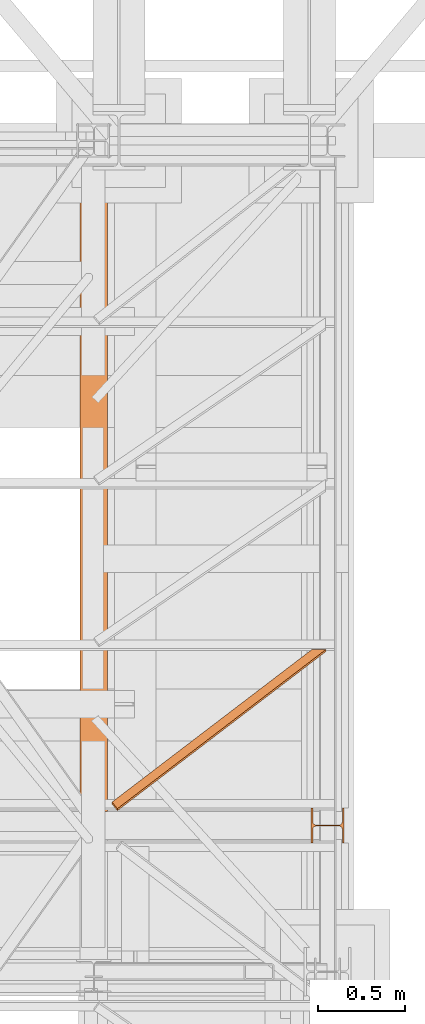
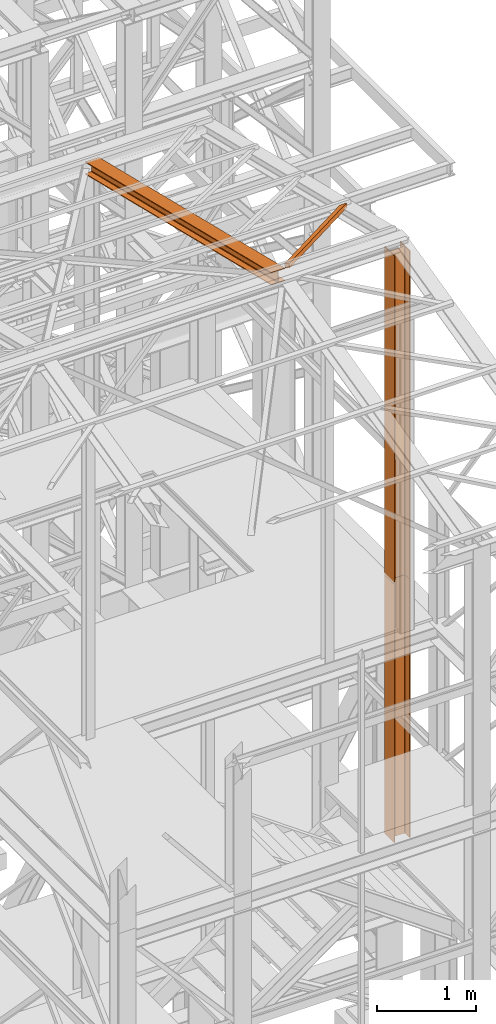
# One storey, part 65 of 208: 4 proxies.
"""IFC2X3 building model written with IfcOpenShell, lengths in millimetres."""

from ifc_helpers import new_model, entity, si_unit, converted_unit, frame, origin, origin_with_axes, place, context, subcontext, project, spatial, faceted_brep, element, save


model = new_model("IFC2X3")

# Units and contexts
model_context = context("Model", 3, precision=1e-05, world=origin())
plan_context = context("Plan", 3, precision=1e-05, world=origin())
body_context = subcontext(model_context, "Body", "Model", "MODEL_VIEW")
ifc_project = project(units=[si_unit("LENGTHUNIT", "METRE", prefix="MILLI"), converted_unit("PLANEANGLEUNIT", "DEGREE", entity("IfcPlaneAngleMeasure", 0.0174532925199433), si_unit("PLANEANGLEUNIT", "RADIAN"), dimensions=[0, 0, 0, 0, 0, 0, 0]), si_unit("AREAUNIT", "SQUARE_METRE"), si_unit("VOLUMEUNIT", "CUBIC_METRE")], contexts=[model_context, plan_context])

# Building, storey
building_placement = place(None, origin())
building = spatial("IfcBuilding", under=ifc_project, at=building_placement, CompositionType="COMPLEX")
storey_placement = place(building_placement, origin_with_axes())
storey = spatial("IfcBuildingStorey", under=building, at=storey_placement, Name="Geschoss", CompositionType="ELEMENT")

# Proxies
proxy_1_placement = place(storey_placement, frame((6603.254953595133, -21317.574391808, 5284.990005364416), z_axis=(0.0, 0.0, 1.0), x_axis=(1.0, 0.0, 0.0)))
element("IfcBuildingElementProxy", 1, at=proxy_1_placement, inside=storey, context=body_context, shape_type="Brep", body=[
    faceted_brep([(0.01000000000021828, 0.00999999999839929, 3200.009996721741), (0.01000000000021828, 200.0100029802306, 3200.009996721741), (10.00999791383765, 200.0100029802306, 3200.009996721741), (10.01000536441825, 121.2600035762771, 3200.009996721741), (11.87455041170142, 111.9441915473326, 3200.009996721741), (18.69419349193595, 105.1245498640819, 3200.009996721741), (28.01000458955787, 103.2600015571697, 3200.009996721741), (162.0100153779986, 103.2600015571697, 3200.009996721741), (171.3258264756205, 105.1245498640819, 3200.009996721741), (178.145469555855, 111.9441915473326, 3200.009996721741), (180.0100146031382, 121.2600035762771, 3200.009996721741), (180.0100146031382, 200.0100029802306, 3200.009996721741), (190.0100125169756, 200.0100029802306, 3200.009996721741), (190.0100125169756, 0.00999999999839929, 3200.009996721741), (180.0100146031382, 0.00999999999839929, 3200.009996721741), (180.0100146031382, 78.75999940395195, 3200.009996721741), (178.145469555855, 88.07581143289644, 3200.009996721741), (171.3258264756205, 94.89545311614711, 3200.009996721741), (162.0100153779986, 96.7600014230593, 3200.009996721741), (28.01000458955787, 96.7600014230593, 3200.009996721741), (18.69419349193595, 94.89545311614711, 3200.009996721741), (11.87455041170142, 88.07581143289644, 3200.009996721741), (10.01000536441825, 78.75999940395195, 3200.009996721741), (10.00999791383765, 0.00999999999839929, 3200.009996721741), (0.01000000000021828, 200.0100029802306, 3200.009996721741), (0.01000000000021828, 0.00999999999839929, 3200.009996721741), (0.01000000000021828, 0.00999999999839929, 0.009999999999308784), (0.01000000000021828, 200.0100029802306, 0.009999999999308784), (10.00999791383765, 200.0100029802306, 3200.009996721741), (0.01000000000021828, 200.0100029802306, 3200.009996721741), (0.01000000000021828, 200.0100029802306, 0.009999999999308784), (10.00999791383765, 200.0100029802306, 0.009999999999308784), (10.01000536441825, 121.2600035762771, 3200.009996721741), (10.00999791383765, 200.0100029802306, 3200.009996721741), (10.00999791383765, 200.0100029802306, 0.009999999999308784), (10.01000536441825, 121.2600035762771, 0.009999999999308784), (11.87455041170142, 111.9441915473326, 3200.009996721741), (10.01000536441825, 121.2600035762771, 3200.009996721741), (10.01000536441825, 121.2600035762771, 0.009999999999308784), (11.87455041170142, 111.9441915473326, 0.009999999999308784), (18.69419349193595, 105.1245498640819, 3200.009996721741), (11.87455041170142, 111.9441915473326, 3200.009996721741), (11.87455041170142, 111.9441915473326, 0.009999999999308784), (18.69419349193595, 105.1245498640819, 0.009999999999308784), (28.01000458955787, 103.2600015571697, 3200.009996721741), (18.69419349193595, 105.1245498640819, 3200.009996721741), (18.69419349193595, 105.1245498640819, 0.009999999999308784), (28.01000458955787, 103.2600015571697, 0.009999999999308784), (162.0100153779986, 103.2600015571697, 3200.009996721741), (28.01000458955787, 103.2600015571697, 3200.009996721741), (28.01000458955787, 103.2600015571697, 0.009999999999308784), (162.0100153779986, 103.2600015571697, 0.009999999999308784), (171.3258264756205, 105.1245498640819, 3200.009996721741), (162.0100153779986, 103.2600015571697, 3200.009996721741), (162.0100153779986, 103.2600015571697, 0.009999999999308784), (171.3258264756205, 105.1245498640819, 0.009999999999308784), (178.145469555855, 111.9441915473326, 3200.009996721741), (171.3258264756205, 105.1245498640819, 3200.009996721741), (171.3258264756205, 105.1245498640819, 0.009999999999308784), (178.145469555855, 111.9441915473326, 0.009999999999308784), (180.0100146031382, 121.2600035762771, 3200.009996721741), (178.145469555855, 111.9441915473326, 3200.009996721741), (178.145469555855, 111.9441915473326, 0.009999999999308784), (180.0100146031382, 121.2600035762771, 0.009999999999308784), (180.0100146031382, 200.0100029802306, 3200.009996721741), (180.0100146031382, 121.2600035762771, 3200.009996721741), (180.0100146031382, 121.2600035762771, 0.009999999999308784), (180.0100146031382, 200.0100029802306, 0.009999999999308784), (190.0100125169756, 200.0100029802306, 3200.009996721741), (180.0100146031382, 200.0100029802306, 3200.009996721741), (180.0100146031382, 200.0100029802306, 0.009999999999308784), (190.0100125169756, 200.0100029802306, 0.009999999999308784), (190.0100125169756, 0.00999999999839929, 3200.009996721741), (190.0100125169756, 200.0100029802306, 3200.009996721741), (190.0100125169756, 200.0100029802306, 0.009999999999308784), (190.0100125169756, 0.00999999999839929, 0.009999999999308784), (180.0100146031382, 0.00999999999839929, 3200.009996721741), (190.0100125169756, 0.00999999999839929, 3200.009996721741), (190.0100125169756, 0.00999999999839929, 0.009999999999308784), (180.0100146031382, 0.00999999999839929, 0.009999999999308784), (180.0100146031382, 78.75999940395195, 3200.009996721741), (180.0100146031382, 0.00999999999839929, 3200.009996721741), (180.0100146031382, 0.00999999999839929, 0.009999999999308784), (180.0100146031382, 78.75999940395195, 0.009999999999308784), (178.145469555855, 88.07581143289644, 3200.009996721741), (180.0100146031382, 78.75999940395195, 3200.009996721741), (180.0100146031382, 78.75999940395195, 0.009999999999308784), (178.145469555855, 88.07581143289644, 0.009999999999308784), (171.3258264756205, 94.89545311614711, 3200.009996721741), (178.145469555855, 88.07581143289644, 3200.009996721741), (178.145469555855, 88.07581143289644, 0.009999999999308784), (171.3258264756205, 94.89545311614711, 0.009999999999308784), (162.0100153779986, 96.7600014230593, 3200.009996721741), (171.3258264756205, 94.89545311614711, 3200.009996721741), (171.3258264756205, 94.89545311614711, 0.009999999999308784), (162.0100153779986, 96.7600014230593, 0.009999999999308784), (28.01000458955787, 96.7600014230593, 3200.009996721741), (162.0100153779986, 96.7600014230593, 3200.009996721741), (162.0100153779986, 96.7600014230593, 0.009999999999308784), (28.01000458955787, 96.7600014230593, 0.009999999999308784), (18.69419349193595, 94.89545311614711, 3200.009996721741), (28.01000458955787, 96.7600014230593, 3200.009996721741), (28.01000458955787, 96.7600014230593, 0.009999999999308784), (18.69419349193595, 94.89545311614711, 0.009999999999308784), (11.87455041170142, 88.07581143289644, 3200.009996721741), (18.69419349193595, 94.89545311614711, 3200.009996721741), (18.69419349193595, 94.89545311614711, 0.009999999999308784), (11.87455041170142, 88.07581143289644, 0.009999999999308784), (10.01000536441825, 78.75999940395195, 3200.009996721741), (11.87455041170142, 88.07581143289644, 3200.009996721741), (11.87455041170142, 88.07581143289644, 0.009999999999308784), (10.01000536441825, 78.75999940395195, 0.009999999999308784), (10.00999791383765, 0.00999999999839929, 3200.009996721741), (10.01000536441825, 78.75999940395195, 3200.009996721741), (10.01000536441825, 78.75999940395195, 0.009999999999308784), (10.00999791383765, 0.00999999999839929, 0.009999999999308784), (0.01000000000021828, 0.00999999999839929, 3200.009996721741), (10.00999791383765, 0.00999999999839929, 3200.009996721741), (10.00999791383765, 0.00999999999839929, 0.009999999999308784), (0.01000000000021828, 0.00999999999839929, 0.009999999999308784), (0.01000000000021828, 0.00999999999839929, 0.009999999999308784), (10.00999791383765, 0.00999999999839929, 0.009999999999308784), (10.01000536441825, 78.75999940395195, 0.009999999999308784), (11.87455041170142, 88.07581143289644, 0.009999999999308784), (18.69419349193595, 94.89545311614711, 0.009999999999308784), (28.01000458955787, 96.7600014230593, 0.009999999999308784), (162.0100153779986, 96.7600014230593, 0.009999999999308784), (171.3258264756205, 94.89545311614711, 0.009999999999308784), (178.145469555855, 88.07581143289644, 0.009999999999308784), (180.0100146031382, 78.75999940395195, 0.009999999999308784), (180.0100146031382, 0.00999999999839929, 0.009999999999308784), (190.0100125169756, 0.00999999999839929, 0.009999999999308784), (190.0100125169756, 200.0100029802306, 0.009999999999308784), (180.0100146031382, 200.0100029802306, 0.009999999999308784), (180.0100146031382, 121.2600035762771, 0.009999999999308784), (178.145469555855, 111.9441915473326, 0.009999999999308784), (171.3258264756205, 105.1245498640819, 0.009999999999308784), (162.0100153779986, 103.2600015571697, 0.009999999999308784), (28.01000458955787, 103.2600015571697, 0.009999999999308784), (18.69419349193595, 105.1245498640819, 0.009999999999308784), (11.87455041170142, 111.9441915473326, 0.009999999999308784), (10.01000536441825, 121.2600035762771, 0.009999999999308784), (10.00999791383765, 200.0100029802306, 0.009999999999308784), (0.01000000000021828, 200.0100029802306, 0.009999999999308784)], [[[0, 1, 2, 3, 4, 5, 6, 7, 8, 9, 10, 11, 12, 13, 14, 15, 16, 17, 18, 19, 20, 21, 22, 23]], [[24, 25, 26, 27]], [[28, 29, 30, 31]], [[32, 33, 34, 35]], [[36, 37, 38, 39]], [[40, 41, 42, 43]], [[44, 45, 46, 47]], [[48, 49, 50, 51]], [[52, 53, 54, 55]], [[56, 57, 58, 59]], [[60, 61, 62, 63]], [[64, 65, 66, 67]], [[68, 69, 70, 71]], [[72, 73, 74, 75]], [[76, 77, 78, 79]], [[80, 81, 82, 83]], [[84, 85, 86, 87]], [[88, 89, 90, 91]], [[92, 93, 94, 95]], [[96, 97, 98, 99]], [[100, 101, 102, 103]], [[104, 105, 106, 107]], [[108, 109, 110, 111]], [[112, 113, 114, 115]], [[116, 117, 118, 119]], [[120, 121, 122, 123, 124, 125, 126, 127, 128, 129, 130, 131, 132, 133, 134, 135, 136, 137, 138, 139, 140, 141, 142, 143]]], orient=[[False], [False], [False], [False], [False], [False], [False], [False], [False], [False], [False], [False], [False], [False], [False], [False], [False], [False], [False], [False], [False], [False], [False], [False], [False], [False]]),
])
proxy_2_placement = place(storey_placement, frame((6603.25496227017, -21317.57439178015, 8484.990002086157), z_axis=(0.0, 0.0, 1.0), x_axis=(1.0, 0.0, 0.0)))
element("IfcBuildingElementProxy", 2, at=proxy_2_placement, inside=storey, context=body_context, shape_type="Brep", body=[
    faceted_brep([(0.01000000000021828, 0.01000864719753736, 4065.914535727219), (0.01000000000021828, 200.0100116274298, 4065.914535727219), (10.00999791383765, 200.0100116274298, 4065.914535727219), (10.01000536441825, 121.2600122234762, 4065.914535727219), (11.87455041170142, 111.9442001945317, 4065.914535727219), (18.69419349193595, 105.1245585112811, 4065.914535727219), (28.01000458955787, 103.2600102043689, 4065.914535727219), (162.0100153779986, 103.2600102043689, 4065.914535727219), (171.3258264756205, 105.1245585112811, 4065.914535727219), (178.145469555855, 111.9442001945317, 4065.914535727219), (180.0100146031382, 121.2600122234762, 4065.914535727219), (180.0100146031382, 200.0100116274298, 4065.914535727219), (190.0100125169756, 200.0100116274298, 4065.914535727219), (190.0100125169756, 0.01000864719753736, 4065.914535727219), (180.0100146031382, 0.01000864719753736, 4065.914535727219), (180.0100146031382, 78.76000805115109, 4065.914535727219), (178.145469555855, 88.07582008009558, 4065.914535727219), (171.3258264756205, 94.89546176334625, 4065.914535727219), (162.0100153779986, 96.76001007025843, 4065.914535727219), (28.01000458955787, 96.76001007025843, 4065.914535727219), (18.69419349193595, 94.89546176334625, 4065.914535727219), (11.87455041170142, 88.07582008009558, 4065.914535727219), (10.01000536441825, 78.76000805115109, 4065.914535727219), (10.00999791383765, 0.01000864719753736, 4065.914535727219), (0.01000000000021828, 200.0100116274298, 4065.914535727219), (0.01000000000021828, 0.01000864719753736, 4065.914535727219), (0.01000000000021828, 0.01000000000203727, 0.01000000000021828), (0.01000000000021828, 200.0100029802343, 0.01000000000021828), (10.00999791383765, 200.0100116274298, 4065.914535727219), (0.01000000000021828, 200.0100116274298, 4065.914535727219), (0.01000000000021828, 200.0100029802343, 0.01000000000021828), (10.00999791383765, 200.0100029802343, 0.01000000000021828), (10.01000536441825, 121.2600122234762, 4065.914535727219), (10.00999791383765, 200.0100116274298, 4065.914535727219), (10.00999791383765, 200.0100029802343, 0.01000000000021828), (10.01000536441825, 121.2600035762807, 0.01000000000021828), (11.87455041170142, 111.9442001945317, 4065.914535727219), (10.01000536441825, 121.2600122234762, 4065.914535727219), (10.01000536441825, 121.2600035762807, 0.01000000000021828), (11.87455041170142, 111.9441915473362, 0.01000000000021828), (18.69419349193595, 105.1245585112811, 4065.914535727219), (11.87455041170142, 111.9442001945317, 4065.914535727219), (11.87455041170142, 111.9441915473362, 0.01000000000021828), (18.69419349193595, 105.1245498640856, 0.01000000000021828), (28.01000458955787, 103.2600102043689, 4065.914535727219), (18.69419349193595, 105.1245585112811, 4065.914535727219), (18.69419349193595, 105.1245498640856, 0.01000000000021828), (28.01000458955787, 103.2600015571734, 0.01000000000021828), (162.0100153779986, 103.2600102043689, 4065.914535727219), (28.01000458955787, 103.2600102043689, 4065.914535727219), (28.01000458955787, 103.2600015571734, 0.01000000000021828), (162.0100153779986, 103.2600015571734, 0.01000000000021828), (171.3258264756205, 105.1245585112811, 4065.914535727219), (162.0100153779986, 103.2600102043689, 4065.914535727219), (162.0100153779986, 103.2600015571734, 0.01000000000021828), (171.3258264756205, 105.1245498640856, 0.01000000000021828), (178.145469555855, 111.9442001945317, 4065.914535727219), (171.3258264756205, 105.1245585112811, 4065.914535727219), (171.3258264756205, 105.1245498640856, 0.01000000000021828), (178.145469555855, 111.9441915473362, 0.01000000000021828), (180.0100146031382, 121.2600122234762, 4065.914535727219), (178.145469555855, 111.9442001945317, 4065.914535727219), (178.145469555855, 111.9441915473362, 0.01000000000021828), (180.0100146031382, 121.2600035762807, 0.01000000000021828), (180.0100146031382, 200.0100116274298, 4065.914535727219), (180.0100146031382, 121.2600122234762, 4065.914535727219), (180.0100146031382, 121.2600035762807, 0.01000000000021828), (180.0100146031382, 200.0100029802343, 0.01000000000021828), (190.0100125169756, 200.0100116274298, 4065.914535727219), (180.0100146031382, 200.0100116274298, 4065.914535727219), (180.0100146031382, 200.0100029802343, 0.01000000000021828), (190.0100125169756, 200.0100029802343, 0.01000000000021828), (190.0100125169756, 0.01000864719753736, 4065.914535727219), (190.0100125169756, 200.0100116274298, 4065.914535727219), (190.0100125169756, 200.0100029802343, 0.01000000000021828), (190.0100125169756, 0.01000000000203727, 0.01000000000021828), (180.0100146031382, 0.01000864719753736, 4065.914535727219), (190.0100125169756, 0.01000864719753736, 4065.914535727219), (190.0100125169756, 0.01000000000203727, 0.01000000000021828), (180.0100146031382, 0.01000000000203727, 0.01000000000021828), (180.0100146031382, 78.76000805115109, 4065.914535727219), (180.0100146031382, 0.01000864719753736, 4065.914535727219), (180.0100146031382, 0.01000000000203727, 0.01000000000021828), (180.0100146031382, 78.75999940395559, 0.01000000000021828), (178.145469555855, 88.07582008009558, 4065.914535727219), (180.0100146031382, 78.76000805115109, 4065.914535727219), (180.0100146031382, 78.75999940395559, 0.01000000000021828), (178.145469555855, 88.07581143290008, 0.01000000000021828), (171.3258264756205, 94.89546176334625, 4065.914535727219), (178.145469555855, 88.07582008009558, 4065.914535727219), (178.145469555855, 88.07581143290008, 0.01000000000021828), (171.3258264756205, 94.89545311615075, 0.01000000000021828), (162.0100153779986, 96.76001007025843, 4065.914535727219), (171.3258264756205, 94.89546176334625, 4065.914535727219), (171.3258264756205, 94.89545311615075, 0.01000000000021828), (162.0100153779986, 96.76000142306293, 0.01000000000021828), (28.01000458955787, 96.76001007025843, 4065.914535727219), (162.0100153779986, 96.76001007025843, 4065.914535727219), (162.0100153779986, 96.76000142306293, 0.01000000000021828), (28.01000458955787, 96.76000142306293, 0.01000000000021828), (18.69419349193595, 94.89546176334625, 4065.914535727219), (28.01000458955787, 96.76001007025843, 4065.914535727219), (28.01000458955787, 96.76000142306293, 0.01000000000021828), (18.69419349193595, 94.89545311615075, 0.01000000000021828), (11.87455041170142, 88.07582008009558, 4065.914535727219), (18.69419349193595, 94.89546176334625, 4065.914535727219), (18.69419349193595, 94.89545311615075, 0.01000000000021828), (11.87455041170142, 88.07581143290008, 0.01000000000021828), (10.01000536441825, 78.76000805115109, 4065.914535727219), (11.87455041170142, 88.07582008009558, 4065.914535727219), (11.87455041170142, 88.07581143290008, 0.01000000000021828), (10.01000536441825, 78.75999940395559, 0.01000000000021828), (10.00999791383765, 0.01000864719753736, 4065.914535727219), (10.01000536441825, 78.76000805115109, 4065.914535727219), (10.01000536441825, 78.75999940395559, 0.01000000000021828), (10.00999791383765, 0.01000000000203727, 0.01000000000021828), (0.01000000000021828, 0.01000864719753736, 4065.914535727219), (10.00999791383765, 0.01000864719753736, 4065.914535727219), (10.00999791383765, 0.01000000000203727, 0.01000000000021828), (0.01000000000021828, 0.01000000000203727, 0.01000000000021828), (0.01000000000021828, 0.01000000000203727, 0.01000000000021828), (10.00999791383765, 0.01000000000203727, 0.01000000000021828), (10.01000536441825, 78.75999940395559, 0.01000000000021828), (11.87455041170142, 88.07581143290008, 0.01000000000021828), (18.69419349193595, 94.89545311615075, 0.01000000000021828), (28.01000458955787, 96.76000142306293, 0.01000000000021828), (162.0100153779986, 96.76000142306293, 0.01000000000021828), (171.3258264756205, 94.89545311615075, 0.01000000000021828), (178.145469555855, 88.07581143290008, 0.01000000000021828), (180.0100146031382, 78.75999940395559, 0.01000000000021828), (180.0100146031382, 0.01000000000203727, 0.01000000000021828), (190.0100125169756, 0.01000000000203727, 0.01000000000021828), (190.0100125169756, 200.0100029802343, 0.01000000000021828), (180.0100146031382, 200.0100029802343, 0.01000000000021828), (180.0100146031382, 121.2600035762807, 0.01000000000021828), (178.145469555855, 111.9441915473362, 0.01000000000021828), (171.3258264756205, 105.1245498640856, 0.01000000000021828), (162.0100153779986, 103.2600015571734, 0.01000000000021828), (28.01000458955787, 103.2600015571734, 0.01000000000021828), (18.69419349193595, 105.1245498640856, 0.01000000000021828), (11.87455041170142, 111.9441915473362, 0.01000000000021828), (10.01000536441825, 121.2600035762807, 0.01000000000021828), (10.00999791383765, 200.0100029802343, 0.01000000000021828), (0.01000000000021828, 200.0100029802343, 0.01000000000021828)], [[[0, 1, 2, 3, 4, 5, 6, 7, 8, 9, 10, 11, 12, 13, 14, 15, 16, 17, 18, 19, 20, 21, 22, 23]], [[24, 25, 26, 27]], [[28, 29, 30, 31]], [[32, 33, 34, 35]], [[36, 37, 38, 39]], [[40, 41, 42, 43]], [[44, 45, 46, 47]], [[48, 49, 50, 51]], [[52, 53, 54, 55]], [[56, 57, 58, 59]], [[60, 61, 62, 63]], [[64, 65, 66, 67]], [[68, 69, 70, 71]], [[72, 73, 74, 75]], [[76, 77, 78, 79]], [[80, 81, 82, 83]], [[84, 85, 86, 87]], [[88, 89, 90, 91]], [[92, 93, 94, 95]], [[96, 97, 98, 99]], [[100, 101, 102, 103]], [[104, 105, 106, 107]], [[108, 109, 110, 111]], [[112, 113, 114, 115]], [[116, 117, 118, 119]], [[120, 121, 122, 123, 124, 125, 126, 127, 128, 129, 130, 131, 132, 133, 134, 135, 136, 137, 138, 139, 140, 141, 142, 143]]], orient=[[False], [False], [False], [False], [False], [False], [False], [False], [False], [False], [False], [False], [False], [False], [False], [False], [False], [False], [False], [False], [False], [False], [False], [False], [False], [False]]),
])
proxy_3_placement = place(storey_placement, frame((5268.254966591513, -21137.57438465545, 11628.70515179705), z_axis=(0.0, 0.0, 1.0), x_axis=(1.0, 0.0, 0.0)))
element("IfcBuildingElementProxy", 3, at=proxy_3_placement, inside=storey, context=body_context, shape_type="Brep", body=[
    faceted_brep([(160.0100113248891, 0.01000000000203727, 1074.775244917653), (0.01000000000658474, 0.01000000000203727, 1074.775244917653), (0.01000000000021828, 3780.009979404025, 156.4315054631916), (160.01001132488, 3780.009979404025, 156.4315054631916), (0.01000000000658474, 0.01000000000203727, 1074.775244917653), (0.01000000000658474, 0.01000000000203727, 1065.513442427271), (0.01000000000021828, 3780.009979404025, 147.1697029728093), (0.01000000000021828, 3780.009979404025, 156.4315054631916), (0.01000000000658474, 0.01000000000203727, 1065.513442427271), (62.01000457466216, 0.01000000000203727, 1065.513442427271), (62.01000457465671, 3780.009979404025, 147.1697029728093), (0.01000000000021828, 3780.009979404025, 147.1697029728093), (62.01000457466216, 0.01000000000203727, 1065.513442427271), (69.77318079978795, 0.01000000000203727, 1063.914455819968), (69.77318079977886, 3780.009979404025, 145.5707163655079), (62.01000457465671, 3780.009979404025, 147.1697029728093), (69.77318079978795, 0.01000000000203727, 1063.914455819968), (75.45621545822087, 0.01000000000203727, 1058.066108594254), (75.45621545821086, 3780.009979404025, 139.7223691397903), (69.77318079977886, 3780.009979404025, 145.5707163655079), (75.45621545822087, 0.01000000000203727, 1058.066108594254), (77.0100056363699, 0.01000000000203727, 1050.077113888498), (77.0100056363608, 3780.009979404025, 131.7333744340358), (75.45621545821086, 3780.009979404025, 139.7223691397903), (77.0100056363699, 0.01000000000203727, 1050.077113888498), (77.0100056363699, 0.01000000000203727, 943.0518743172743), (77.0100056363608, 3780.009979404025, 24.70813486281259), (77.0100056363608, 3780.009979404025, 131.7333744340358), (77.0100056363699, 0.01000000000203727, 943.0518743172743), (75.45621545821996, 0.01000000000203727, 935.0628757778613), (75.45621545821086, 3780.009979404025, 16.71913632339965), (77.0100056363608, 3780.009979404025, 24.70813486281259), (75.45621545821996, 0.01000000000203727, 935.0628757778613), (69.77318079978795, 0.01000000000203727, 929.2145285521474), (69.77318079977886, 3780.009979404025, 10.87078909768752), (75.45621545821086, 3780.009979404025, 16.71913632339965), (69.77318079978795, 0.01000000000203727, 929.2145285521474), (62.01000457466216, 0.01000000000203727, 927.6155419448442), (62.01000457465307, 3780.009979404025, 9.27180249038247), (69.77318079977886, 3780.009979404025, 10.87078909768752), (62.01000457466216, 0.01000000000203727, 927.6155419448442), (0.01000000000658474, 0.01000000000203727, 927.6155419448423), (0.01000000000021828, 3780.009979404025, 9.27180249038247), (62.01000457465307, 3780.009979404025, 9.27180249038247), (0.01000000000658474, 0.01000000000203727, 927.6155419448423), (0.01000000000567525, 0.01000000000203727, 918.3537394544601), (0.01000000000021828, 3780.009979404025, 0.01000000000021828), (0.01000000000021828, 3780.009979404025, 9.27180249038247), (0.01000000000567525, 0.01000000000203727, 918.3537394544601), (160.0100113248891, 0.01000000000203727, 918.3537394544619), (160.0100113248827, 3780.009979404025, 0.01000000000021828), (0.01000000000021828, 3780.009979404025, 0.01000000000021828), (160.0100113248891, 0.01000000000203727, 918.3537394544619), (160.0100113248891, 0.01000000000203727, 927.6155419448423), (160.0100113248836, 3780.009979404025, 9.27180249038065), (160.0100113248827, 3780.009979404025, 0.01000000000021828), (160.0100113248891, 0.01000000000203727, 927.6155419448423), (98.0100067502317, 0.01000000000203727, 927.6155419448423), (98.0100067502226, 3780.009979404025, 9.27180249038247), (160.0100113248836, 3780.009979404025, 9.27180249038065), (98.0100067502317, 0.01000000000203727, 927.6155419448423), (90.2468305251059, 0.01000000000203727, 929.2145285521474), (90.24683052509681, 3780.009979404025, 10.87078909768752), (98.0100067502226, 3780.009979404025, 9.27180249038247), (90.2468305251059, 0.01000000000203727, 929.2145285521474), (84.5637958666739, 0.01000000000203727, 935.0628757778613), (84.5637958666648, 3780.009979404025, 16.71913632339783), (90.24683052509681, 3780.009979404025, 10.87078909768752), (84.5637958666739, 0.01000000000203727, 935.0628757778613), (83.01000568852396, 0.01000000000203727, 943.0518743172743), (83.01000568851487, 3780.009979404025, 24.70813486281077), (84.5637958666648, 3780.009979404025, 16.71913632339783), (83.01000568852396, 0.01000000000203727, 943.0518743172743), (83.01000568852396, 0.01000000000203727, 1050.077113888496), (83.01000568851578, 3780.009979404025, 131.733374434034), (83.01000568851487, 3780.009979404025, 24.70813486281077), (83.01000568852396, 0.01000000000203727, 1050.077113888496), (84.56379586667481, 0.01000000000203727, 1058.066108594254), (84.5637958666648, 3780.009979404025, 139.7223691397903), (83.01000568851578, 3780.009979404025, 131.733374434034), (84.56379586667481, 0.01000000000203727, 1058.066108594254), (90.24683052510682, 0.01000000000203727, 1063.914455819968), (90.24683052509772, 3780.009979404025, 145.5707163655079), (84.5637958666648, 3780.009979404025, 139.7223691397903), (90.24683052510682, 0.01000000000203727, 1063.914455819968), (98.0100067502317, 0.01000000000203727, 1065.513442427271), (98.0100067502226, 3780.009979404025, 147.1697029728093), (90.24683052509772, 3780.009979404025, 145.5707163655079), (98.0100067502317, 0.01000000000203727, 1065.513442427271), (160.0100113248891, 0.01000000000203727, 1065.513442427271), (160.0100113248836, 3780.009979404025, 147.1697029728093), (98.0100067502226, 3780.009979404025, 147.1697029728093), (160.0100113248891, 0.01000000000203727, 1065.513442427271), (160.0100113248891, 0.01000000000203727, 1074.775244917653), (160.01001132488, 3780.009979404025, 156.4315054631916), (160.0100113248836, 3780.009979404025, 147.1697029728093), (0.01000000000658474, 0.01000000000203727, 1074.775244917653), (160.0100113248891, 0.01000000000203727, 1074.775244917653), (160.0100113248891, 0.01000000000203727, 1065.513442427271), (98.0100067502317, 0.01000000000203727, 1065.513442427271), (90.24683052510682, 0.01000000000203727, 1063.914455819968), (84.56379586667481, 0.01000000000203727, 1058.066108594254), (83.01000568852396, 0.01000000000203727, 1050.077113888496), (83.01000568852396, 0.01000000000203727, 943.0518743172743), (84.5637958666739, 0.01000000000203727, 935.0628757778613), (90.2468305251059, 0.01000000000203727, 929.2145285521474), (98.0100067502317, 0.01000000000203727, 927.6155419448423), (160.0100113248891, 0.01000000000203727, 927.6155419448423), (160.0100113248891, 0.01000000000203727, 918.3537394544619), (0.01000000000567525, 0.01000000000203727, 918.3537394544601), (0.01000000000658474, 0.01000000000203727, 927.6155419448423), (62.01000457466216, 0.01000000000203727, 927.6155419448442), (69.77318079978795, 0.01000000000203727, 929.2145285521474), (75.45621545821996, 0.01000000000203727, 935.0628757778613), (77.0100056363699, 0.01000000000203727, 943.0518743172743), (77.0100056363699, 0.01000000000203727, 1050.077113888498), (75.45621545822087, 0.01000000000203727, 1058.066108594254), (69.77318079978795, 0.01000000000203727, 1063.914455819968), (62.01000457466216, 0.01000000000203727, 1065.513442427271), (0.01000000000658474, 0.01000000000203727, 1065.513442427271), (160.01001132488, 3780.009979404025, 156.4315054631916), (0.01000000000021828, 3780.009979404025, 156.4315054631916), (0.01000000000021828, 3780.009979404025, 147.1697029728093), (62.01000457465671, 3780.009979404025, 147.1697029728093), (69.77318079977886, 3780.009979404025, 145.5707163655079), (75.45621545821086, 3780.009979404025, 139.7223691397903), (77.0100056363608, 3780.009979404025, 131.7333744340358), (77.0100056363608, 3780.009979404025, 24.70813486281259), (75.45621545821086, 3780.009979404025, 16.71913632339965), (69.77318079977886, 3780.009979404025, 10.87078909768752), (62.01000457465307, 3780.009979404025, 9.27180249038247), (0.01000000000021828, 3780.009979404025, 9.27180249038247), (0.01000000000021828, 3780.009979404025, 0.01000000000021828), (160.0100113248827, 3780.009979404025, 0.01000000000021828), (160.0100113248836, 3780.009979404025, 9.27180249038065), (98.0100067502226, 3780.009979404025, 9.27180249038247), (90.24683052509681, 3780.009979404025, 10.87078909768752), (84.5637958666648, 3780.009979404025, 16.71913632339783), (83.01000568851487, 3780.009979404025, 24.70813486281077), (83.01000568851578, 3780.009979404025, 131.733374434034), (84.5637958666648, 3780.009979404025, 139.7223691397903), (90.24683052509772, 3780.009979404025, 145.5707163655079), (98.0100067502226, 3780.009979404025, 147.1697029728093), (160.0100113248836, 3780.009979404025, 147.1697029728093)], [[[0, 1, 2, 3]], [[4, 5, 6, 7]], [[8, 9, 10, 11]], [[12, 13, 14, 15]], [[16, 17, 18, 19]], [[20, 21, 22, 23]], [[24, 25, 26, 27]], [[28, 29, 30, 31]], [[32, 33, 34, 35]], [[36, 37, 38, 39]], [[40, 41, 42, 43]], [[44, 45, 46, 47]], [[48, 49, 50, 51]], [[52, 53, 54, 55]], [[56, 57, 58, 59]], [[60, 61, 62, 63]], [[64, 65, 66, 67]], [[68, 69, 70, 71]], [[72, 73, 74, 75]], [[76, 77, 78, 79]], [[80, 81, 82, 83]], [[84, 85, 86, 87]], [[88, 89, 90, 91]], [[92, 93, 94, 95]], [[96, 97, 98, 99, 100, 101, 102, 103, 104, 105, 106, 107, 108, 109, 110, 111, 112, 113, 114, 115, 116, 117, 118, 119]], [[120, 121, 122, 123, 124, 125, 126, 127, 128, 129, 130, 131, 132, 133, 134, 135, 136, 137, 138, 139, 140, 141, 142, 143]]], orient=[[False], [False], [False], [False], [False], [False], [False], [False], [False], [False], [False], [False], [False], [False], [False], [False], [False], [False], [False], [False], [False], [False], [False], [False], [False], [False]]),
])
proxy_4_placement = place(storey_placement, frame((5453.266212211913, -21131.89943305478, 12452.48424969946), z_axis=(0.0, 0.0, 1.0), x_axis=(1.0, 0.0, 0.0)))
element("IfcBuildingElementProxy", 4, at=proxy_4_placement, inside=storey, context=body_context, shape_type="Brep", body=[
    faceted_brep([(30.90667059062071, 0.00999999999839929, 226.4986808683661), (0.01000000000021828, 38.27547330550806, 217.4903902913557), (0.2573532659844204, 49.92204982994736, 266.1144180103966), (31.15402385660491, 11.65657652443406, 275.1227085874107), (1236.33656313946, 919.9906357924301, 0.00999999999839929), (30.90667059062071, 0.00999999999839929, 226.4986808683661), (31.15402385660491, 11.65657652443406, 275.1227085874107), (1236.776755192319, 931.784386325784, 48.59779516605158), (1155.425219966553, 920.0850544678724, 0.3989852722497744), (0.01000000000021828, 38.27547330550806, 217.4903902913557), (30.90667059062071, 0.00999999999839929, 226.4986808683661), (1236.33656313946, 919.9906357924301, 0.00999999999839929), (1155.865412019412, 931.8788050012263, 48.98678043829932), (0.2573532659844204, 49.92204982994736, 266.1144180103966), (0.01000000000021828, 38.27547330550806, 217.4903902913557), (1155.425219966553, 920.0850544678724, 0.3989852722497744), (1236.776755192319, 931.784386325784, 48.59779516605158), (31.15402385660491, 11.65657652443406, 275.1227085874107), (0.2573532659844204, 49.92204982994736, 266.1144180103966), (1155.865412019412, 931.8788050012263, 48.98678043829932), (1236.33656313946, 919.9906357924301, 0.00999999999839929), (1236.776755192319, 931.784386325784, 48.59779516605158), (1155.865412019412, 931.8788050012263, 48.98678043829932), (1155.425219966553, 920.0850544678724, 0.3989852722497744)], [[[0, 1, 2, 3]], [[4, 5, 6, 7]], [[8, 9, 10, 11]], [[12, 13, 14, 15]], [[16, 17, 18, 19]], [[20, 21, 22, 23]]], orient=[[False], [False], [False], [False], [False], [False]]),
])

save(model, "model.ifc")
